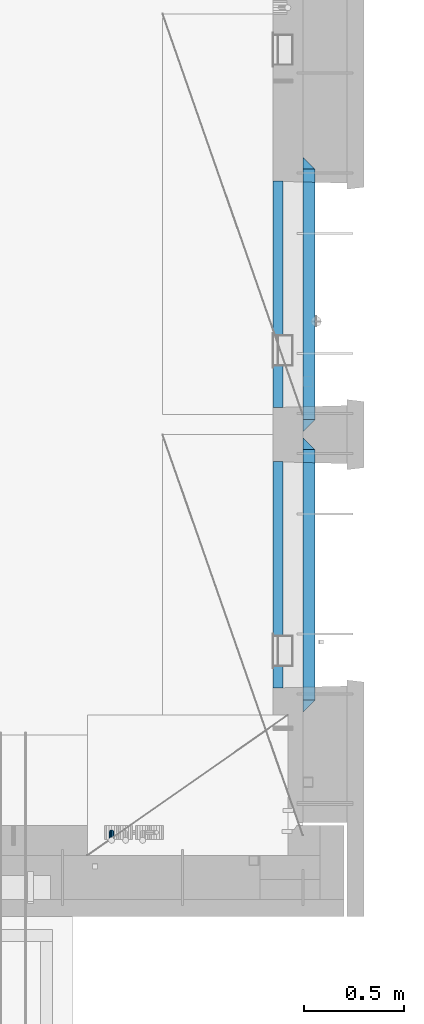
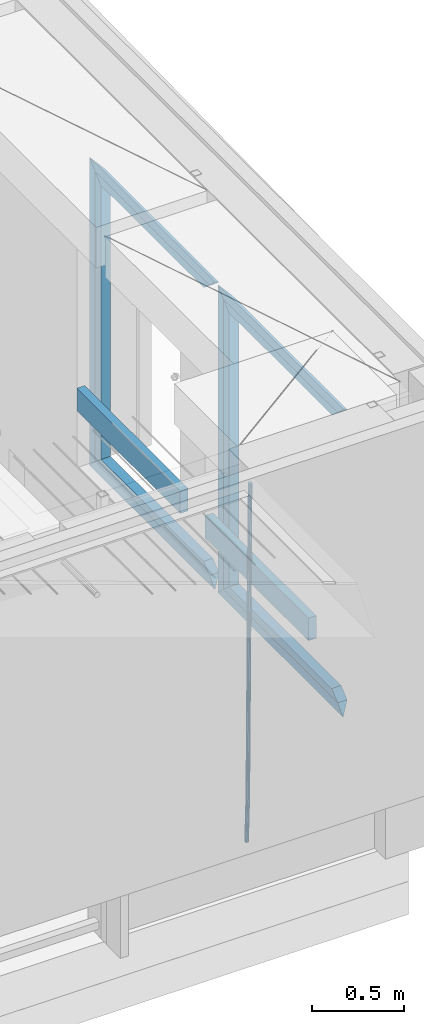
# One storey, part 113 of 325: 15 beams, 2 elements without a shape of their own.
"""IFC2X3 building model written with IfcOpenShell, lengths in millimetres."""

import ifcopenshell
import ifcopenshell.guid

model = None  # the IFC model being written
_history = None  # IfcOwnerHistory: only IFC2X3 demands one
_inside = {}  # id of a spatial element -> (the spatial element, [elements in it])
_under = {}  # id of a project, library or spatial element -> (it, [spatial elements below it])
_declared = {}  # id of a project -> (the project, [libraries it declares])
_typed = {}  # id of a type object -> (the type object, [elements of that type])
_made_of = {}  # id of a material, layer set ... -> (it, [elements and type objects made of it])


def new_model(schema):
    """Start an empty IFC model of exactly this schema.

    Asked for "IFC4X3", IfcOpenShell would pick the latest addendum, in which some entities
    have other attributes; the version numbers below select the first issue.
    IFC2X3 requires an IfcOwnerHistory on every rooted entity: one is made here for all.
    """
    global model, _history
    if schema == "IFC4X3":
        model = ifcopenshell.file(schema_version=(4, 3, 0, 0))
    else:
        model = ifcopenshell.file(schema=schema)
    _inside.clear()
    _under.clear()
    _declared.clear()
    _typed.clear()
    _made_of.clear()
    _history = None
    if model.schema == "IFC2X3":
        org = make("IfcOrganization", Name="unknown")
        user = make(
            "IfcPersonAndOrganization",
            ThePerson=make("IfcPerson", FamilyName="unknown"),
            TheOrganization=org,
        )
        app = make(
            "IfcApplication",
            ApplicationDeveloper=org,
            Version="unknown",
            ApplicationFullName="unknown",
            ApplicationIdentifier="unknown",
        )
        _history = make(
            "IfcOwnerHistory",
            OwningUser=user,
            OwningApplication=app,
            ChangeAction="ADDED",
            CreationDate=0,
        )
    return model


def make(cls, **values):
    """One entity of the class cls with the attributes given. An attribute that is None is left unset."""
    return model.create_entity(
        cls, **{name: value for name, value in values.items() if value is not None}
    )


def rooted(cls, **values):
    """An entity with a GlobalId (a new one), such as an element, a storey or a relation."""
    return make(cls, GlobalId=ifcopenshell.guid.new(), OwnerHistory=_history, **values)


def si_unit(unit_type, name, prefix=None):
    """IfcSIUnit, for example si_unit("LENGTHUNIT", "METRE", prefix="MILLI")."""
    return make("IfcSIUnit", UnitType=unit_type, Prefix=prefix, Name=name)


def assignment(units):
    """IfcUnitAssignment: the units of a project."""
    return None if units is None else make("IfcUnitAssignment", Units=units)


def point(xyz):
    """IfcCartesianPoint."""
    return None if xyz is None else make("IfcCartesianPoint", Coordinates=xyz)


def direction(xyz):
    """IfcDirection."""
    return None if xyz is None else make("IfcDirection", DirectionRatios=xyz)


def frame(location, z_axis=None, x_axis=None):
    """IfcAxis2Placement3D, a coordinate frame: its origin and axes. An axis left out is left unset."""
    return make(
        "IfcAxis2Placement3D",
        Location=point(location),
        Axis=direction(z_axis),
        RefDirection=direction(x_axis),
    )


def origin_with_axes():
    """The frame at (0, 0, 0) with the z axis (0, 0, 1) and the x axis (1, 0, 0) written out."""
    return frame((0.0, 0.0, 0.0), z_axis=(0.0, 0.0, 1.0), x_axis=(1.0, 0.0, 0.0))


def place(relative_to, where):
    """IfcLocalPlacement: puts the frame where relative to a parent placement (None: the world)."""
    return make(
        "IfcLocalPlacement", PlacementRelTo=relative_to, RelativePlacement=where
    )


def context(
    kind, dimensions, precision=None, world=None, true_north=None, identifier=None
):
    """IfcGeometricRepresentationContext, for example the 3D "Model" context."""
    return make(
        "IfcGeometricRepresentationContext",
        ContextIdentifier=identifier,
        ContextType=kind,
        CoordinateSpaceDimension=dimensions,
        Precision=precision,
        WorldCoordinateSystem=world,
        TrueNorth=true_north,
    )


def subcontext(parent, identifier, kind, view, scale=None):
    """IfcGeometricRepresentationSubContext, for example "Body" below "Model"."""
    return make(
        "IfcGeometricRepresentationSubContext",
        ContextIdentifier=identifier,
        ContextType=kind,
        ParentContext=parent,
        TargetScale=scale,
        TargetView=view,
    )


def project(units=None, contexts=None):
    """IfcProject with its units and contexts."""
    return rooted(
        "IfcProject",
        Name="project",
        RepresentationContexts=contexts,
        UnitsInContext=assignment(units),
    )


def spatial(cls, under=None, at=None, **own):
    """A site, building, storey or space (cls), placed at a placement, below another one or the project."""
    s = rooted(cls, ObjectPlacement=at, **own)
    if under is not None:
        _under.setdefault(under.id(), (under, []))[1].append(s)
    return s


def faces_of(points, faces, orient=None, outer=None):
    """IfcFace entities. A face is a list of loops; a loop is a list of indices into points, from 0.

    orient and outer hold one flag for each loop. By default every Orientation is true, the
    first loop of a face is its IfcFaceOuterBound and the others are IfcFaceBound.
    """
    made = []
    for i, loops in enumerate(faces):
        bounds = []
        for j, loop in enumerate(loops):
            is_outer = j == 0 if outer is None else outer[i][j]
            bounds.append(
                make(
                    "IfcFaceOuterBound" if is_outer else "IfcFaceBound",
                    Bound=make("IfcPolyLoop", Polygon=[points[k] for k in loop]),
                    Orientation=True if orient is None else orient[i][j],
                )
            )
        made.append(make("IfcFace", Bounds=bounds))
    return made


def faceted_brep(points, faces, orient=None, outer=None, voids=None):
    """IfcFacetedBrep: a solid bounded by flat faces; with voids (closed shells), ...WithVoids."""
    shared = [point(p) for p in points]
    hull = make("IfcClosedShell", CfsFaces=faces_of(shared, faces, orient, outer))
    if voids is None:
        return make("IfcFacetedBrep", Outer=hull)
    return make(
        "IfcFacetedBrepWithVoids",
        Outer=hull,
        Voids=[
            make(cls, CfsFaces=faces_of(shared, fs, o, b)) for cls, fs, o, b in voids
        ],
    )


def shape(context_of_items, identifier, shape_type, items):
    """IfcShapeRepresentation: the items that make up one representation, for example the "Body"."""
    return make(
        "IfcShapeRepresentation",
        ContextOfItems=context_of_items,
        RepresentationIdentifier=identifier,
        RepresentationType=shape_type,
        Items=items,
    )


def material(Name=None, Category=None):
    """IfcMaterial."""
    return make("IfcMaterial", Name=Name, Category=Category)


def made_of(thing, what):
    """Note that an element or type object is made of a material, layer set ...; save() writes the relation."""
    if what is not None:
        _made_of.setdefault(what.id(), (what, []))[1].append(thing)
    return thing


def type_object(cls, material=None, **own):
    """A type object (cls), such as IfcWallType, which elements share."""
    return made_of(rooted(cls, **own), material)


def element(
    cls,
    number,
    at=None,
    inside=None,
    cuts=None,
    type_object=None,
    material=None,
    context=None,
    identifier="Body",
    shape_type=None,
    held_by="IfcProductDefinitionShape",
    body=None,
    shapes=None,
    **own,
):
    """One element of the class cls, such as IfcWall. Its Tag is "e" and its number.

    at: its placement. inside: the storey or other place that contains it. cuts: it is an
    opening in that element (IfcRelVoidsElement). A single representation is given by context,
    identifier, shape_type and body (its items); several are given by shapes. held_by: the class
    of the entity that holds the representations. save() writes the other relations.
    """
    e = rooted(cls, Tag="e%d" % number, ObjectPlacement=at, **own)
    if body is not None:
        shapes = [shape(context, identifier, shape_type, body)]
    if shapes is not None:
        e.Representation = make(held_by, Representations=shapes)
    if inside is not None:
        _inside.setdefault(inside.id(), (inside, []))[1].append(e)
    if cuts is not None:
        rooted(
            "IfcRelVoidsElement", RelatingBuildingElement=cuts, RelatedOpeningElement=e
        )
    if type_object is not None:
        _typed.setdefault(type_object.id(), (type_object, []))[1].append(e)
    return made_of(e, material)


def aggregate(whole, parts):
    """IfcRelAggregates: a whole, such as a stair, and the parts it consists of."""
    return rooted("IfcRelAggregates", RelatingObject=whole, RelatedObjects=parts)


def save(model, path):
    """Write the relations noted so far, then the file.

    IfcRelAggregates (storeys below a building ...), IfcRelContainedInSpatialStructure (elements
    in a storey), IfcRelDefinesByType, IfcRelAssociatesMaterial and IfcRelDeclares: one each for
    every whole, place, type object, material and project.
    """
    for whole, parts in _under.values():
        aggregate(whole, parts)
    for where, things in _inside.values():
        rooted(
            "IfcRelContainedInSpatialStructure",
            RelatedElements=things,
            RelatingStructure=where,
        )
    for kind, things in _typed.values():
        rooted("IfcRelDefinesByType", RelatedObjects=things, RelatingType=kind)
    for what, things in _made_of.values():
        rooted("IfcRelAssociatesMaterial", RelatedObjects=things, RelatingMaterial=what)
    for by, libraries in _declared.values():
        rooted("IfcRelDeclares", RelatingContext=by, RelatedDefinitions=libraries)
    model.write(path)


model = new_model("IFC2X3")

# Units and contexts
model_context = context("Model", 3, precision=1e-05, world=origin_with_axes())
body_context = subcontext(model_context, "Body", "Model", "MODEL_VIEW")
ifc_project = project(units=[si_unit("LENGTHUNIT", "METRE", prefix="MILLI"), si_unit("AREAUNIT", "SQUARE_METRE"), si_unit("VOLUMEUNIT", "CUBIC_METRE"), si_unit("MASSUNIT", "GRAM", prefix="KILO"), si_unit("TIMEUNIT", "SECOND"), si_unit("PLANEANGLEUNIT", "RADIAN"), si_unit("SOLIDANGLEUNIT", "STERADIAN"), si_unit("THERMODYNAMICTEMPERATUREUNIT", "DEGREE_CELSIUS"), si_unit("LUMINOUSINTENSITYUNIT", "LUMEN")], contexts=[model_context])

# Site, building, storey
site_placement = place(None, origin_with_axes())
site = spatial("IfcSite", under=ifc_project, at=site_placement, CompositionType="ELEMENT")
building_placement = place(site_placement, origin_with_axes())
building = spatial("IfcBuilding", under=site, at=building_placement, CompositionType="ELEMENT")
storey_placement = place(building_placement, origin_with_axes())
storey = spatial("IfcBuildingStorey", under=building, at=storey_placement, Name="1", CompositionType="ELEMENT", Elevation=0.0)

# Assembly, beam
assembly_1_placement = place(storey_placement, origin_with_axes())
assembly_1 = element("IfcElementAssembly", 1, at=assembly_1_placement, inside=storey, AssemblyPlace="NOTDEFINED", PredefinedType="REINFORCEMENT_UNIT")
ifc_material_1 = material()
beam_type_1 = type_object("IfcBeamType", Name="D25", PredefinedType="NOTDEFINED")
beam_1_placement = place(assembly_1_placement, frame((34104.9999999961, 7965.00000227913, 81990.0), z_axis=(0.00020576299992186, -0.999642804629538, -0.0267249099901004), x_axis=(-4.30000201928125e-08, -0.0267249099948059, 0.999642825806181)))
beam_1 = element("IfcBeam", 2, at=beam_1_placement, type_object=beam_type_1, material=ifc_material_1, Name="JM25", ObjectType="D25", context=body_context, shape_type="Brep", body=[
    faceted_brep([(-7.41420080885291e-08, -12.5, -3.63797880709171e-12), (-6.42030499875546e-08, -10.8253175473074, -6.25000000000364), (60.4103898235917, -10.8253175318459, -6.2499999938409), (60.4103898269532, -12.4999999845422, 6.16273609921336e-09), (-3.70782800018787e-08, -6.25000000000364, -10.8253175473074), (60.4103898202884, -6.24999998454587, -10.8253175411446), (-1.45519152283669e-11, -3.63797880709171e-12, -12.5), (60.4103898179019, 1.54577719513327e-08, -12.4999999938373), (3.70637280866504e-08, 6.25, -10.8253175473074), (60.410389817087, 6.25000001545777, -10.825317541141), (6.42030499875546e-08, 10.8253175473001, -6.25000000000364), (60.410389818062, 10.8253175627578, -6.24999999383726), (7.41420080885291e-08, 12.4999999999927, 0.0), (60.4103898205503, 12.5000000154541, 6.16273609921336e-09), (6.42176019027829e-08, 10.8253175473001, 6.24999999999636), (60.4103898238973, 10.8253175627651, 6.2500000061591), (3.70928319171071e-08, 6.24999999999636, 10.8253175473037), (60.4103898272151, 6.25000001546141, 10.8253175534664), (1.45519152283669e-11, -3.63797880709171e-12, 12.4999999999964), (60.4103898296162, 1.54541339725256e-08, 12.5000000061591), (-3.7049176171422e-08, -6.25000000000364, 10.8253175473001), (60.4103898304165, -6.24999998454587, 10.8253175534701), (-6.41884980723262e-08, -10.8253175473074, 6.25), (60.4103898294561, -10.8253175318459, 6.25000000616637), (61.0324985728803, -10.8253175316895, -6.24999999377542), (60.991802792938, -12.4999999843931, 6.22458173893392e-09), (61.0622854283865, -6.24999998437852, -10.8253175410755), (61.0731819955545, 1.5628756955266e-08, -12.4999999937718), (61.0622685480339, 6.25000001562512, -10.8253175410791), (61.032469335245, 10.8253175629216, -6.24999999377178), (60.9917690322181, 12.5000000156033, 6.22458173893392e-09), (60.9510732522613, 10.8253175629034, 6.25000000621731), (60.9212863967696, 6.25000001558874, 10.8253175535247), (60.9103898296162, 1.55814632307738e-08, 12.5000000062137), (60.9213032771368, -6.24999998441126, 10.8253175535174), (60.9511024898966, -10.8253175317113, 6.25000000621731), (61.6545545670233, -10.8253158516927, -6.24189838219536), (61.573166454793, -12.499998414296, 0.00757164385504439), (61.7141257553885, -6.24999822394238, -10.8168280205282), (61.7359179680789, 1.80548886419274e-06, -12.491368569139), (61.7140919992817, 6.25000177601396, -10.8168282403167), (61.6544960997562, 10.8253192428383, -6.2418987628771), (61.5730989426083, 12.5000015856094, 0.0075712042817031), (61.4917108303925, 10.8253190230062, 6.25704123032847), (61.4321396420273, 6.25000139525582, 10.8319708686649), (61.4103474293224, 1.36582457344048e-06, 12.5065114172721), (61.4321733981196, -6.24999860470052, 10.8319710884571), (61.4917692976451, -10.8253160715249, 6.25704161101385), (176.524302641745, -10.8250056210964, -4.74584321979273), (176.442914529529, -12.4996881836996, 1.50362680625403), (176.583873830095, -6.24968799334965, -9.3207728581292), (176.605666042786, 0.000312036081595579, -10.9953134067364), (176.583840074018, 6.25031200660669, -9.32077307791769), (176.524244174492, 10.8256294734347, -4.74584360047811), (176.44284701733, 12.5003118162058, 1.50362636668069), (176.361458905099, 10.8256292535989, 7.75309639272746), (176.301887716749, 6.25031162585219, 12.3280260310676), (176.280095504058, 0.000311596420942806, 14.0025665796711), (176.301921472827, -6.24968837410415, 12.3280262508561), (176.361517372367, -10.8250058409321, 7.75309677341284), (177.085397012124, -10.8250041057399, -4.73853556792164), (176.983633547483, -12.4996867233749, 1.51066909103247), (177.159881729676, -6.24968643771717, -9.31327097355097), (177.187129580227, 0.000313606451527448, -10.987740468332), (177.159839524218, 6.25031356221734, -9.31327130338468), (177.085323910098, 10.8256309887511, -4.73853613920801), (176.983549136537, 12.5003132764905, 1.51066843136869), (176.881785671867, 10.8256306588555, 7.7598730903228), (176.80730095433, 6.25031299082912, 12.3346084959521), (176.780053103794, 0.000312946667690994, 14.0090779907332), (176.807343159802, -6.2496870091054, 12.3346088257895), (176.881858773908, -10.8250044356355, 7.7598736616128), (177.646431799818, -10.8250018318176, -4.72756919822132), (177.524295146417, -12.4996845320202, 1.52123723245313), (177.735828462886, -6.24968410334986, -9.30201312475765), (177.768531371941, 0.00031596292683389, -10.9763759912421), (177.735777808921, 6.25031589654827, -9.30201361973741), (177.646344064575, 10.8256332626152, -4.72757005553649), (177.524193838486, 12.5003154677688, 1.52123624250817), (177.402057185071, 10.8256327675663, 7.77004267317898), (177.312660521988, 6.2503150390985, 12.3444865997226), (177.279957612933, 0.00031497282179771, 14.0188494661961), (177.312711175953, -6.24968496079964, 12.3444870946951), (177.402144920314, -10.8250023268702, 7.77004353049415), (299.377443161706, -10.8245084454466, -2.34813158632096), (299.255306508276, -12.4991911456491, 3.90067484435349), (299.466839824803, -6.24919071697514, -6.92257551286093), (299.499542733873, 0.0008093492979242, -8.59693837933446), (299.466789170867, 6.250809282923, -6.92257600783341), (299.377355426492, 10.8261266489935, -2.34813244364341), (299.255205200388, 12.5008088541435, 3.90067385440125), (299.133068546944, 10.826126153941, 10.1494802850757), (299.043671883861, 6.25080842546959, 14.7239242116229), (299.010968974762, 0.000808359200163977, 16.3982870780892), (299.043722537797, -6.24919157442127, 14.7239247065918), (299.133156282158, -10.8245089404954, 10.1494811423981), (299.98561436501, -10.8245059804758, -2.33624385599614), (299.97179243555, -12.4991882411778, 3.91467976726199), (299.995742293278, -6.24918857328521, -6.91223722345239), (299.999447243041, 0.000811375455668895, -8.58716690387519), (299.995736475976, 6.25081142679483, -6.91223684201032), (299.985604289133, 10.8261291142808, -2.33624319533556), (299.971750386685, 12.5008117588586, 3.91467993563856), (299.957928457196, 10.8261294971744, 10.1656035610831), (299.947800528913, 6.25081208998381, 14.7415969285394), (299.944095579151, 0.00081214124293183, 16.4165266089549), (299.947806346216, -6.24918791008895, 14.7415965471009), (299.957938533058, -10.8245055975785, 10.1656029004225), (300.593832239858, -10.8245078794353, -2.34543881707941), (300.688302931099, -12.4991904788549, 3.90384712594823), (300.524685350189, -6.24919022474205, -6.92023371784308), (300.499390115292, 0.000809814544481924, -8.59472497713432), (300.524724372954, 6.25080977519247, -6.92023401429469), (300.593899829313, 10.8261272150703, -2.34543933054374), (300.688380976673, 12.5008095210287, 3.90384653304136), (300.782851667915, 10.8261269216127, 10.1531324760799), (300.851998557599, 6.25080926691589, 14.7279273768363), (300.877293792495, 0.000809227632998955, 16.4024186361276), (300.851959534804, -6.24919073302226, 14.7279276732806), (300.782784078474, -10.8245081728965, 10.153132989537), (2293.32930409742, -10.8307295605009, -32.4713622331001), (2293.42377478865, -12.5054121599169, -26.2220762900724), (2293.26015720774, -6.2554119058077, -37.0461571338565), (2293.23486197284, -0.00541186651753378, -38.7206483931477), (2293.26019623051, 6.24458809413409, -37.0461574303008), (2293.32937168686, 10.8199055340046, -32.4713627465644), (2293.42385283421, 12.4945878399631, -26.2220768829684), (2293.51832352545, 10.8199052405434, -19.972790939948), (2293.58747041514, 6.24458758585388, -15.3979960391844), (2293.61276565003, -0.00541245343265473, -13.7235047798931), (2293.58743139236, -6.25541241408428, -15.3979957427327), (2293.51825593603, -10.8307298539585, -19.9727904264691), (2294.0420846676, -10.8307317859326, -32.4821379598216), (2294.03681932652, -12.5054140739521, -26.2313442200393), (2294.06778164886, -6.2554144273563, -37.0583666982457), (2294.10702478497, -0.00541458957013674, -38.7338336404937), (2294.14929890928, 6.24458531819619, -37.0595987724118), (2294.18327670435, 10.8199028679592, -32.4842719748667), (2294.1998538474, 12.4945854171456, -26.2338083683717), (2294.19458850632, 10.819903129126, -19.9830146285858), (2294.16889152506, 6.24458577054975, -15.4067858901581), (2294.12964838895, -0.0054140672327776, -13.7313189479173), (2294.08737426462, -6.2554139749991, -15.4055538159919), (2294.05339646956, -10.8307315247621, -19.9808806135297), (2294.75482297382, -10.84002603931, -32.4726521173216), (2294.64982751427, -12.513407826169, -26.2231856868602), (2294.87535820232, -6.26594539088183, -37.0476186524102), (2294.97913588268, -0.0167870967634371, -38.7222267036377), (2295.0383488692, 6.23299192477134, -37.0477663960555), (2295.03713108998, 10.8087684320271, -32.4729080168181), (2294.97580884799, 12.4844668051373, -26.2234811741473), (2294.87081338844, 10.8110850182784, -19.9740147436787), (2294.7502781599, 6.23700436985018, -15.3990482086047), (2294.64650047956, -0.0121539242718427, -13.7244401573698), (2294.58728749304, -6.26193294580662, -15.3989004649666), (2294.58850527227, -10.8377094530588, -19.9737588441894), (2316.44667268227, -11.1228921988077, -32.1839550346631), (2316.34167722271, -12.7962739856739, -25.9344886042054), (2316.56720791078, -6.54881155039038, -36.7589215697517), (2316.67098559113, -0.299653256264719, -38.4335296209792), (2316.73019857766, 5.95012576527006, -36.759069313397), (2316.72898079845, 10.5259022725259, -32.1842109341669), (2316.66765855643, 12.2016006456361, -25.9347840914961), (2316.56266309689, 10.5282188587698, -19.6853176610275), (2316.44212786836, 5.95413821035254, -15.1103511259389), (2316.33835018802, -0.295020083769487, -13.4357430747186), (2316.27913720149, -6.54479910530426, -15.1102033823008), (2316.28035498071, -11.1205756125637, -19.685061761531), (2317.13234804722, -11.1318335458927, -32.1748293731798), (2317.04181141085, -12.8054038787741, -25.9251705100723), (2317.2154741603, -6.5572650749491, -36.7502937866229), (2317.26891617525, -0.307450393454928, -38.4255717558117), (2317.27835434731, 5.94297770185585, -36.7517739018112), (2317.24125972588, 10.5192220504723, -32.1773930078925), (2317.16757178486, 12.1950816748285, -25.9281307404563), (2317.0770351485, 10.5215113419545, -19.6784718773561), (2316.99390903539, 5.94694287101083, -15.1030074639057), (2316.94046702047, -0.302871810494253, -13.4277294947169), (2316.9310288484, -6.55329990579412, -15.1015273487101), (2316.96812346982, -11.1295442544142, -19.6759082426288), (2317.81808136747, -11.1298054502913, -32.1659056455355), (2317.74200467508, -12.803315894289, -25.9160547315114), (2317.86379538118, -6.55536082026447, -36.7418676070083), (2317.8668976831, -0.305700748642266, -38.417815303761), (2317.82655701396, 5.94458339541234, -36.7446799039099), (2317.75358262347, 10.5207330230332, -32.1707766866384), (2317.66752794063, 12.1965725370646, -25.9216793252963), (2317.59145124823, 10.5230620930706, -19.6718284112721), (2317.54573723453, 5.94861746304377, -15.0958664497994), (2317.54263493262, -0.301042608574789, -13.4199187530394), (2317.58297560175, -6.55132675263303, -15.0930541529051), (2317.65594999224, -11.1274763802539, -19.6669573701693), (2417.81884292323, -10.831603083323, -30.8687911350135), (2417.74276623082, -12.505113527317, -24.618940220982), (2417.86455693691, -6.25715845329614, -35.4447530964935), (2417.86765923884, -0.00749838167394046, -37.1207007932499), (2417.82731856969, 6.24278576237703, -35.4475653933878), (2417.75434417921, 10.8189353900088, -30.8736621761236), (2417.66828949639, 12.494774904033, -24.6245648147851), (2417.59221280397, 10.8212644600353, -18.3747139007501), (2417.54649879028, 6.2468198300121, -13.79875193927), (2417.54339648837, -0.00284024161010166, -12.1228042425173), (2417.5837371575, -6.25312438566107, -13.795939642383), (2417.65671154798, -10.8292740132893, -18.3698428596399)], [[[0, 1, 2, 3]], [[1, 4, 5, 2]], [[4, 6, 7, 5]], [[6, 8, 9, 7]], [[8, 10, 11, 9]], [[10, 12, 13, 11]], [[12, 14, 15, 13]], [[14, 16, 17, 15]], [[16, 18, 19, 17]], [[18, 20, 21, 19]], [[20, 22, 23, 21]], [[22, 0, 3, 23]], [[22, 20, 18, 16, 14, 12, 10, 8, 6, 4, 1, 0]], [[3, 2, 24, 25]], [[2, 5, 26, 24]], [[5, 7, 27, 26]], [[7, 9, 28, 27]], [[9, 11, 29, 28]], [[11, 13, 30, 29]], [[13, 15, 31, 30]], [[15, 17, 32, 31]], [[17, 19, 33, 32]], [[19, 21, 34, 33]], [[21, 23, 35, 34]], [[23, 3, 25, 35]], [[25, 24, 36, 37]], [[24, 26, 38, 36]], [[26, 27, 39, 38]], [[27, 28, 40, 39]], [[28, 29, 41, 40]], [[29, 30, 42, 41]], [[30, 31, 43, 42]], [[31, 32, 44, 43]], [[32, 33, 45, 44]], [[33, 34, 46, 45]], [[34, 35, 47, 46]], [[35, 25, 37, 47]], [[37, 36, 48, 49]], [[36, 38, 50, 48]], [[38, 39, 51, 50]], [[39, 40, 52, 51]], [[40, 41, 53, 52]], [[41, 42, 54, 53]], [[42, 43, 55, 54]], [[43, 44, 56, 55]], [[44, 45, 57, 56]], [[45, 46, 58, 57]], [[46, 47, 59, 58]], [[47, 37, 49, 59]], [[49, 48, 60, 61]], [[48, 50, 62, 60]], [[50, 51, 63, 62]], [[51, 52, 64, 63]], [[52, 53, 65, 64]], [[53, 54, 66, 65]], [[54, 55, 67, 66]], [[55, 56, 68, 67]], [[56, 57, 69, 68]], [[57, 58, 70, 69]], [[58, 59, 71, 70]], [[59, 49, 61, 71]], [[61, 60, 72, 73]], [[60, 62, 74, 72]], [[62, 63, 75, 74]], [[63, 64, 76, 75]], [[64, 65, 77, 76]], [[65, 66, 78, 77]], [[66, 67, 79, 78]], [[67, 68, 80, 79]], [[68, 69, 81, 80]], [[69, 70, 82, 81]], [[70, 71, 83, 82]], [[71, 61, 73, 83]], [[73, 72, 84, 85]], [[72, 74, 86, 84]], [[74, 75, 87, 86]], [[75, 76, 88, 87]], [[76, 77, 89, 88]], [[77, 78, 90, 89]], [[78, 79, 91, 90]], [[79, 80, 92, 91]], [[80, 81, 93, 92]], [[81, 82, 94, 93]], [[82, 83, 95, 94]], [[83, 73, 85, 95]], [[85, 84, 96, 97]], [[84, 86, 98, 96]], [[86, 87, 99, 98]], [[87, 88, 100, 99]], [[88, 89, 101, 100]], [[89, 90, 102, 101]], [[90, 91, 103, 102]], [[91, 92, 104, 103]], [[92, 93, 105, 104]], [[93, 94, 106, 105]], [[94, 95, 107, 106]], [[95, 85, 97, 107]], [[97, 96, 108, 109]], [[96, 98, 110, 108]], [[98, 99, 111, 110]], [[99, 100, 112, 111]], [[100, 101, 113, 112]], [[101, 102, 114, 113]], [[102, 103, 115, 114]], [[103, 104, 116, 115]], [[104, 105, 117, 116]], [[105, 106, 118, 117]], [[106, 107, 119, 118]], [[107, 97, 109, 119]], [[109, 108, 120, 121]], [[108, 110, 122, 120]], [[110, 111, 123, 122]], [[111, 112, 124, 123]], [[112, 113, 125, 124]], [[113, 114, 126, 125]], [[114, 115, 127, 126]], [[115, 116, 128, 127]], [[116, 117, 129, 128]], [[117, 118, 130, 129]], [[118, 119, 131, 130]], [[119, 109, 121, 131]], [[121, 120, 132, 133]], [[120, 122, 134, 132]], [[122, 123, 135, 134]], [[123, 124, 136, 135]], [[124, 125, 137, 136]], [[125, 126, 138, 137]], [[126, 127, 139, 138]], [[127, 128, 140, 139]], [[128, 129, 141, 140]], [[129, 130, 142, 141]], [[130, 131, 143, 142]], [[131, 121, 133, 143]], [[133, 132, 144, 145]], [[132, 134, 146, 144]], [[134, 135, 147, 146]], [[135, 136, 148, 147]], [[136, 137, 149, 148]], [[137, 138, 150, 149]], [[138, 139, 151, 150]], [[139, 140, 152, 151]], [[140, 141, 153, 152]], [[141, 142, 154, 153]], [[142, 143, 155, 154]], [[143, 133, 145, 155]], [[145, 144, 156, 157]], [[144, 146, 158, 156]], [[146, 147, 159, 158]], [[147, 148, 160, 159]], [[148, 149, 161, 160]], [[149, 150, 162, 161]], [[150, 151, 163, 162]], [[151, 152, 164, 163]], [[152, 153, 165, 164]], [[153, 154, 166, 165]], [[154, 155, 167, 166]], [[155, 145, 157, 167]], [[157, 156, 168, 169]], [[156, 158, 170, 168]], [[158, 159, 171, 170]], [[159, 160, 172, 171]], [[160, 161, 173, 172]], [[161, 162, 174, 173]], [[162, 163, 175, 174]], [[163, 164, 176, 175]], [[164, 165, 177, 176]], [[165, 166, 178, 177]], [[166, 167, 179, 178]], [[167, 157, 169, 179]], [[169, 168, 180, 181]], [[168, 170, 182, 180]], [[170, 171, 183, 182]], [[171, 172, 184, 183]], [[172, 173, 185, 184]], [[173, 174, 186, 185]], [[174, 175, 187, 186]], [[175, 176, 188, 187]], [[176, 177, 189, 188]], [[177, 178, 190, 189]], [[178, 179, 191, 190]], [[179, 169, 181, 191]], [[181, 180, 192, 193]], [[180, 182, 194, 192]], [[182, 183, 195, 194]], [[183, 184, 196, 195]], [[184, 185, 197, 196]], [[185, 186, 198, 197]], [[186, 187, 199, 198]], [[187, 188, 200, 199]], [[188, 189, 201, 200]], [[189, 190, 202, 201]], [[190, 191, 203, 202]], [[191, 181, 193, 203]], [[194, 195, 196, 197, 198, 199, 200, 201, 202, 203, 193, 192]]]),
])
aggregate(assembly_1, [beam_1])

# Assembly, beams
assembly_2_placement = place(storey_placement, origin_with_axes())
assembly_2 = element("IfcElementAssembly", 3, at=assembly_2_placement, inside=storey, AssemblyPlace="NOTDEFINED", PredefinedType="REINFORCEMENT_UNIT")
ifc_material_2 = material(Name="TIMBER/T24")
beam_type_2 = type_object("IfcBeamType", PredefinedType="NOTDEFINED")
beam_2_placement = place(assembly_2_placement, frame((34935.0002758707, 8685.00118845241, 82685.0), z_axis=(0.0, 0.0, 1.0), x_axis=(0.0, 1.0, 0.0)))
beam_2 = element("IfcBeam", 4, at=beam_2_placement, type_object=beam_type_2, material=ifc_material_2, context=body_context, shape_type="Brep", body=[
    faceted_brep([(-3.63797880709171e-12, 24.9999999999964, -75.0), (-3.63797880709171e-12, 24.9999999999964, 75.0), (1130.0, 25.0, 75.0), (1130.0, 25.0, -75.0), (0.0, -25.0000000000073, 75.0), (1130.0, -25.0, 75.0), (0.0, -25.0000000000073, -75.0), (1130.0, -25.0, -75.0)], [[[0, 1, 2, 3]], [[1, 4, 5, 2]], [[4, 6, 7, 5]], [[6, 0, 3, 7]], [[5, 7, 3, 2]], [[6, 4, 1, 0]]]),
])
beam_3_placement = place(assembly_2_placement, frame((34935.0002758707, 10085.0011884524, 82685.0), z_axis=(0.0, 0.0, 1.0), x_axis=(0.0, 1.0, 0.0)))
beam_3 = element("IfcBeam", 5, at=beam_3_placement, type_object=beam_type_2, material=ifc_material_2, context=body_context, shape_type="Brep", body=[
    faceted_brep([(-3.63797880709171e-12, 24.9999999999964, -75.0), (-3.63797880709171e-12, 24.9999999999964, 75.0), (1130.0, 25.0, 75.0), (1130.0, 25.0, -75.0), (0.0, -25.0000000000073, 75.0), (1130.0, -25.0, 75.0), (0.0, -25.0000000000073, -75.0), (1130.0, -25.0, -75.0)], [[[0, 1, 2, 3]], [[1, 4, 5, 2]], [[4, 6, 7, 5]], [[6, 0, 3, 7]], [[5, 7, 3, 2]], [[6, 4, 1, 0]]]),
])
ifc_material_3 = material(Name="CONCRETE/C25/30")
beam_type_3 = type_object("IfcBeamType", PredefinedType="NOTDEFINED")
beam_4_placement = place(assembly_2_placement, frame((35090.0, 8565.0001381367, 84145.0), z_axis=(0.0, 0.0, -1.0), x_axis=(0.0, 1.0, 0.0)))
beam_4 = element("IfcBeam", 6, at=beam_4_placement, type_object=beam_type_3, material=ifc_material_3, Name="SK", context=body_context, shape_type="Brep", body=[
    faceted_brep([(60.0000000000073, 30.0, 30.0), (0.0, -30.0, -30.0), (60.0000000000073, -30.0, 30.0), (1309.99990463256, 30.0, 30.0), (1369.99990463257, -30.0, -30.0), (1309.99990463256, -30.0, 30.0)], [[[0, 1, 2]], [[1, 0, 3, 4]], [[2, 1, 4, 5]], [[0, 2, 5, 3]], [[4, 3, 5]]]),
])
beam_5_placement = place(assembly_2_placement, frame((35090.0, 8625.0001381367, 84085.0), z_axis=(0.0, 0.0, -1.0), x_axis=(0.0, 1.0, 0.0)))
beam_5 = element("IfcBeam", 7, at=beam_5_placement, type_object=beam_type_3, material=ifc_material_3, Name="SK", context=body_context, shape_type="Brep", body=[
    faceted_brep([(65.6755803082433, 30.0, 25.6756756756804), (64.0539586866216, -30.0, 24.0540540540533), (1185.94585057852, -30.0, 24.0540540540533), (1184.32422895689, 30.0, 25.6756756756804), (65.6755803082433, 30.0, 26.2933545375708), (64.0539586866216, -30.0, 24.9033931479062), (0.0, -30.0, -30.0), (0.0, 30.0, -30.0), (1249.99990463257, 30.0, -30.0), (1249.99990463257, -30.0, -30.0), (1185.94585057852, -30.0, 24.9034748914273), (1184.32422895689, 30.0, 26.293436281092)], [[[0, 1, 2, 3]], [[1, 0, 4, 5]], [[6, 5, 4, 7]], [[6, 7, 8, 9]], [[2, 1, 5, 6, 9, 10]], [[3, 2, 10, 11]], [[7, 4, 0, 3, 11, 8]], [[10, 9, 8, 11]]]),
])
beam_6_placement = place(assembly_2_placement, frame((35090.0, 9905.00004276927, 84175.0), z_axis=(0.0, -1.0, 0.0), x_axis=(0.0, 0.0, -1.0)))
beam_6 = element("IfcBeam", 8, at=beam_6_placement, type_object=beam_type_3, material=ifc_material_3, Name="SK", context=body_context, shape_type="Brep", body=[
    faceted_brep([(60.0000000000073, 30.0, 30.0), (0.0, -30.0, -30.0), (60.0000000000073, -30.0, 30.0), (1995.0, 30.0, 30.0), (2055.0, -30.0, -30.0), (1995.0, -30.0, 30.0)], [[[0, 1, 2]], [[3, 4, 1, 0]], [[4, 5, 2, 1]], [[5, 3, 0, 2]], [[5, 4, 3]]]),
])
beam_7_placement = place(assembly_2_placement, frame((35090.0, 9875.00004276927, 82210.0), z_axis=(0.0, 0.0, 1.0), x_axis=(0.0, -1.0, 0.0)))
beam_7 = element("IfcBeam", 9, at=beam_7_placement, type_object=beam_type_3, material=ifc_material_3, Name="SK", context=body_context, shape_type="Brep", body=[
    faceted_brep([(1185.94594588314, -29.9999988381387, 24.0540541168593), (1184.32432432432, 29.9999988381387, 25.6756756756804), (65.6756756756768, 30.0, 25.6756756756804), (64.0540540540533, -30.0, 24.0540540540533), (1185.94594594595, -30.0, 24.9033931479207), (1184.32432432433, 30.0, 26.2933545375854), (1249.99990463257, -30.0, -30.0), (1249.99990463257, 30.0, -30.0), (0.0, 30.0, -30.0), (65.6756756756768, 30.0, 26.293436281092), (64.0540540540533, -30.0, 24.9034748914419), (0.0, -30.0, -30.0)], [[[0, 1, 2, 3]], [[1, 0, 4, 5]], [[6, 7, 5, 4]], [[2, 1, 5, 7, 8, 9]], [[3, 2, 9, 10]], [[6, 4, 0, 3, 10, 11]], [[11, 8, 7, 6]], [[11, 10, 9, 8]]]),
])
beam_8_placement = place(assembly_2_placement, frame((35090.0, 9935.00004276927, 82150.0), z_axis=(0.0, 0.0, 1.0), x_axis=(0.0, -1.0, 0.0)))
beam_8 = element("IfcBeam", 10, at=beam_8_placement, type_object=beam_type_3, material=ifc_material_3, Name="SK", context=body_context, shape_type="Brep", body=[
    faceted_brep([(1369.99990463257, -30.0, -30.0), (1309.99990463256, 30.0, 30.0), (1309.99990463256, -30.0, 30.0), (60.0000000000073, 30.0, 30.0), (60.0000000000073, -30.0, 30.0), (0.0, -30.0, -30.0)], [[[0, 1, 2]], [[3, 4, 2, 1]], [[4, 5, 0, 2]], [[5, 3, 1, 0]], [[3, 5, 4]]]),
])
beam_9_placement = place(assembly_2_placement, frame((35090.0, 9965.00023350414, 84145.0), z_axis=(0.0, 0.0, -1.0), x_axis=(0.0, 1.0, 0.0)))
beam_9 = element("IfcBeam", 11, at=beam_9_placement, type_object=beam_type_3, material=ifc_material_3, Name="SK", context=body_context, shape_type="Brep", body=[
    faceted_brep([(60.0000000000073, 30.0, 30.0), (0.0, -30.0, -30.0), (60.0000000000073, -30.0, 30.0), (1309.99942779541, 30.0, 30.0), (1369.99942779541, -30.0, -30.0), (1309.99942779541, -30.0, 30.0)], [[[0, 1, 2]], [[1, 0, 3, 4]], [[2, 1, 4, 5]], [[0, 2, 5, 3]], [[4, 3, 5]]]),
])
beam_10_placement = place(assembly_2_placement, frame((35090.0, 10025.0002335041, 84085.0), z_axis=(0.0, 0.0, -1.0), x_axis=(0.0, 1.0, 0.0)))
beam_10 = element("IfcBeam", 12, at=beam_10_placement, type_object=beam_type_3, material=ifc_material_3, Name="SK", context=body_context, shape_type="Brep", body=[
    faceted_brep([(65.6751034710851, 30.0, 25.6756756756804), (64.0534818494634, -30.0, 24.0540540540533), (1185.94537374136, -30.0, 24.0540540540533), (1184.32375211974, 30.0, 25.6756756756804), (65.6751034710851, 30.0, 26.2929458199942), (64.0534818494634, -30.0, 24.9029844303586), (0.0, -30.0, -30.0), (0.0, 30.0, -30.0), (1249.99942779541, 30.0, -30.0), (1249.99942779541, -30.0, -30.0), (1185.94537374136, -30.0, 24.9034748914273), (1184.32375211974, 30.0, 26.293436281092)], [[[0, 1, 2, 3]], [[1, 0, 4, 5]], [[6, 5, 4, 7]], [[6, 7, 8, 9]], [[2, 1, 5, 6, 9, 10]], [[3, 2, 10, 11]], [[7, 4, 0, 3, 11, 8]], [[10, 9, 8, 11]]]),
])
beam_11_placement = place(assembly_2_placement, frame((35090.0, 11304.9996612995, 84175.0), z_axis=(0.0, -1.0, 0.0), x_axis=(0.0, 0.0, -1.0)))
beam_11 = element("IfcBeam", 13, at=beam_11_placement, type_object=beam_type_3, material=ifc_material_3, Name="SK", context=body_context, shape_type="Brep", body=[
    faceted_brep([(60.0000000000073, 30.0, 30.0), (0.0, -30.0, -30.0), (60.0000000000073, -30.0, 30.0), (1995.0, 30.0, 30.0), (2055.0, -30.0, -30.0), (1995.0, -30.0, 30.0)], [[[0, 1, 2]], [[3, 4, 1, 0]], [[4, 5, 2, 1]], [[5, 3, 0, 2]], [[5, 4, 3]]]),
])
beam_12_placement = place(assembly_2_placement, frame((35090.0, 11274.9996612995, 82210.0), z_axis=(0.0, 0.0, 1.0), x_axis=(0.0, -1.0, 0.0)))
beam_12 = element("IfcBeam", 14, at=beam_12_placement, type_object=beam_type_3, material=ifc_material_3, Name="SK", context=body_context, shape_type="Brep", body=[
    faceted_brep([(1185.94594588314, -29.9999988381387, 24.0540541168593), (1184.32432432432, 29.9999988381387, 25.6756756756804), (65.6756756756768, 30.0, 25.6756756756804), (64.0540540540533, -30.0, 24.0540540540533), (1185.94594594595, -30.0, 24.9029844303586), (1184.32432432433, 30.0, 26.2929458200088), (1249.99942779541, -30.0, -30.0), (1249.99942779541, 30.0, -30.0), (0.0, 30.0, -30.0), (65.6756756756768, 30.0, 26.293436281092), (64.0540540540533, -30.0, 24.9034748914419), (0.0, -30.0, -30.0)], [[[0, 1, 2, 3]], [[1, 0, 4, 5]], [[6, 7, 5, 4]], [[2, 1, 5, 7, 8, 9]], [[3, 2, 9, 10]], [[6, 4, 0, 3, 10, 11]], [[11, 8, 7, 6]], [[11, 10, 9, 8]]]),
])
beam_13_placement = place(assembly_2_placement, frame((35090.0, 11334.9996612995, 82150.0), z_axis=(0.0, 0.0, 1.0), x_axis=(0.0, -1.0, 0.0)))
beam_13 = element("IfcBeam", 15, at=beam_13_placement, type_object=beam_type_3, material=ifc_material_3, Name="SK", context=body_context, shape_type="Brep", body=[
    faceted_brep([(1369.99942779541, -30.0, -30.0), (1309.99942779541, 30.0, 30.0), (1309.99942779541, -30.0, 30.0), (60.0000000000073, 30.0, 30.0), (60.0000000000073, -30.0, 30.0), (0.0, -30.0, -30.0)], [[[0, 1, 2]], [[3, 4, 2, 1]], [[4, 5, 0, 2]], [[5, 3, 1, 0]], [[3, 5, 4]]]),
])
beam_type_4 = type_object("IfcBeamType", PredefinedType="NOTDEFINED")
beam_14_placement = place(assembly_2_placement, frame((35090.0, 9840.00004276927, 84115.0), z_axis=(0.0, -1.0, 0.0), x_axis=(0.0, 0.0, -1.0)))
beam_14 = element("IfcBeam", 16, at=beam_14_placement, type_object=beam_type_4, material=ifc_material_3, Name="SK", context=body_context, shape_type="Brep", body=[
    faceted_brep([(0.0, -30.0, -35.0), (54.9034748914273, -30.0, 29.0540540540533), (56.2934362811066, 30.0, 30.6756756756768), (0.0, 30.0, -35.0), (1935.0, 30.0, -35.0), (1935.0, -30.0, -35.0), (1880.09652510857, -30.0, 29.0540540540533), (1878.70656371891, 30.0, 30.6756756756749)], [[[0, 1, 2, 3]], [[4, 5, 0, 3]], [[1, 0, 5, 6]], [[2, 1, 6, 7]], [[3, 2, 7, 4]], [[6, 5, 4, 7]]]),
])
beam_15_placement = place(assembly_2_placement, frame((35090.0, 11239.9996612995, 84115.0), z_axis=(0.0, -1.0, 0.0), x_axis=(0.0, 0.0, -1.0)))
beam_15 = element("IfcBeam", 17, at=beam_15_placement, type_object=beam_type_4, material=ifc_material_3, Name="SK", context=body_context, shape_type="Brep", body=[
    faceted_brep([(0.0, -30.0, -35.0), (54.9034748914273, -30.0, 29.0540540540533), (56.2934362811066, 30.0, 30.6756756756768), (0.0, 30.0, -35.0), (1935.0, 30.0, -35.0), (1935.0, -30.0, -35.0), (1880.09652510857, -30.0, 29.0540540540533), (1878.70656371891, 30.0, 30.6756756756749)], [[[0, 1, 2, 3]], [[4, 5, 0, 3]], [[1, 0, 5, 6]], [[2, 1, 6, 7]], [[3, 2, 7, 4]], [[6, 5, 4, 7]]]),
])
aggregate(assembly_2, [beam_2, beam_3, beam_4, beam_5, beam_6, beam_14, beam_7, beam_8, beam_9, beam_10, beam_11, beam_15, beam_12, beam_13])

save(model, "model.ifc")
